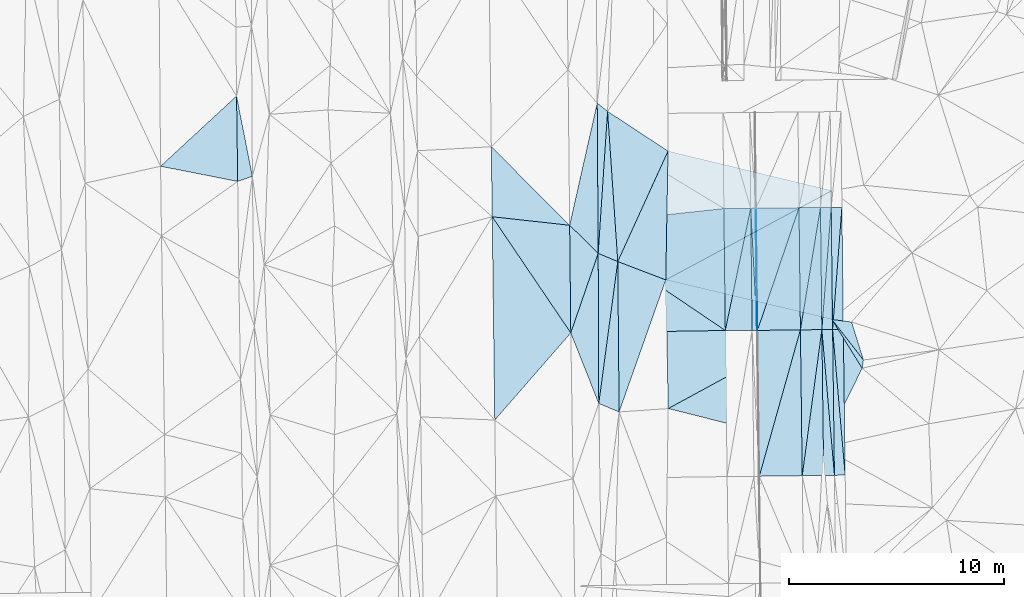
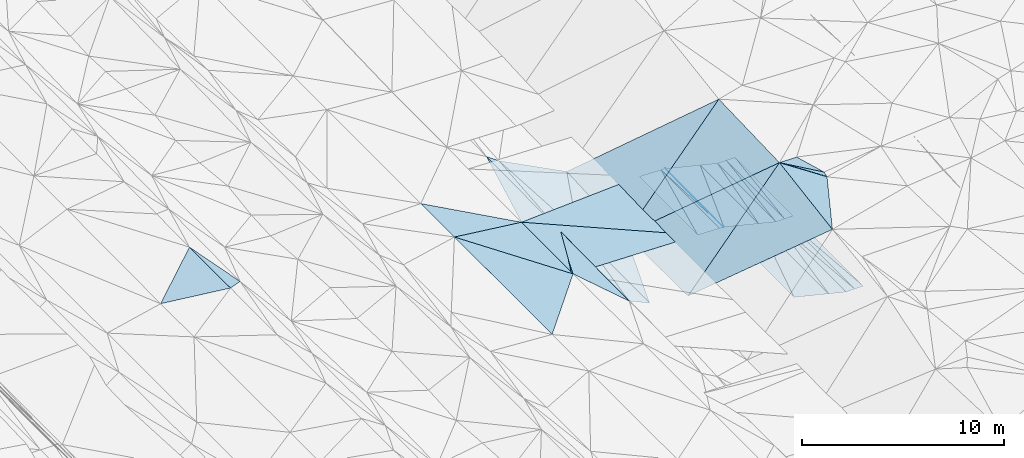
# One storey, part 34 of 275: 46 plates.
"""IFC2X3 building model written with IfcOpenShell, lengths in millimetres."""

from ifc_helpers import new_model, si_unit, frame, origin_with_axes, place, context, subcontext, project, spatial, polyline, outline, extrude, material, type_object, element, save


model = new_model("IFC2X3")

# Units and contexts
model_context = context("Model", 3, precision=1e-05, world=origin_with_axes())
body_context = subcontext(model_context, "Body", "Model", "MODEL_VIEW")
ifc_project = project(units=[si_unit("LENGTHUNIT", "METRE", prefix="MILLI"), si_unit("AREAUNIT", "SQUARE_METRE"), si_unit("VOLUMEUNIT", "CUBIC_METRE"), si_unit("MASSUNIT", "GRAM", prefix="KILO"), si_unit("TIMEUNIT", "SECOND"), si_unit("PLANEANGLEUNIT", "RADIAN"), si_unit("SOLIDANGLEUNIT", "STERADIAN"), si_unit("THERMODYNAMICTEMPERATUREUNIT", "DEGREE_CELSIUS"), si_unit("LUMINOUSINTENSITYUNIT", "LUMEN")], contexts=[model_context])

# Site, building, storey
site_placement = place(None, origin_with_axes())
site = spatial("IfcSite", under=ifc_project, at=site_placement, CompositionType="ELEMENT")
building_placement = place(site_placement, origin_with_axes())
building = spatial("IfcBuilding", under=site, at=building_placement, Name="Undefined", CompositionType="ELEMENT")
storey_placement = place(building_placement, origin_with_axes())
storey = spatial("IfcBuildingStorey", under=building, at=storey_placement, Name="Undefined", CompositionType="ELEMENT", Elevation=0.0)

# Plates
ifc_material = material()
plate_type_1 = type_object("IfcPlateType", PredefinedType="NOTDEFINED")
plate_1_placement = place(storey_placement, frame((-62138.0579087981, 8292.00278589061, 41120.5116137731), z_axis=(-0.213705537159807, 0.0166326658530718, -0.976756519207248), x_axis=(-0.904444932650548, 0.374508364674133, 0.204261715923109)))
element("IfcPlate", 1, at=plate_1_placement, inside=storey, type_object=plate_type_1, material=ifc_material, Name="00", context=body_context, shape_type="SweptSolid", body=[
    extrude(outline(polyline([(0.0, 0.0), (1047.67553710938, 2.97950464300811e-09), (2707.23706054688, 6462.1826171875), (0.0, 0.0)])), frame((-8.85201319254618e-08, 2.18876761149539e-07, -0.5000001331573), z_axis=(0.0, 0.0, 1.0), x_axis=(1.0, 0.0, 0.0)), (0.0, 0.0, 1.0), 1.0),
])
plate_type_2 = type_object("IfcPlateType", PredefinedType="NOTDEFINED")
plate_2_placement = place(storey_placement, frame((-55757.1571306949, 17783.4511288641, 41272.1487525771), z_axis=(-0.0501896607139265, 0.0218036376036795, -0.998501677186708), x_axis=(0.0115225950572727, -0.999682493231415, -0.0224085369840911)))
element("IfcPlate", 2, at=plate_2_placement, inside=storey, type_object=plate_type_2, material=ifc_material, Name="00_PR", context=body_context, shape_type="SweptSolid", body=[
    extrude(outline(polyline([(0.0, 0.0), (5694.8642578125, -3.17959347739816e-09), (5694.85107421875, 20.0251865386963), (0.0, 0.0)])), frame((-8.85201319254618e-08, 2.18876761149539e-07, -0.5000001331573), z_axis=(0.0, 0.0, 1.0), x_axis=(1.0, 0.0, 0.0)), (0.0, 0.0, 1.0), 1.0),
])
plate_3_placement = place(storey_placement, frame((-55711.5356164447, 12090.1551803275, 41145.5347521996), z_axis=(-0.0501703449300262, 0.0218038137157571, -0.998502644061122), x_axis=(-0.0115225950602647, 0.99968249323143, 0.0224085369819156)))
element("IfcPlate", 3, at=plate_3_placement, inside=storey, type_object=plate_type_2, material=ifc_material, Name="00_PR", context=body_context, shape_type="SweptSolid", body=[
    extrude(outline(polyline([(0.0, 0.0), (5694.8828125, -4.78030415251851e-09), (5694.85107421875, 20.0245056152344), (0.0, 0.0)])), frame((-8.85201319254618e-08, 2.18876761149539e-07, -0.5000001331573), z_axis=(0.0, 0.0, 1.0), x_axis=(1.0, 0.0, 0.0)), (0.0, 0.0, 1.0), 1.0),
])
plate_type_3 = type_object("IfcPlateType", PredefinedType="NOTDEFINED")
plate_4_placement = place(storey_placement, frame((-57191.5919974292, 12086.723146007, 41199.3753833085), z_axis=(-0.0323757136217727, 0.021699449340617, -0.999240184873384), x_axis=(-0.0115216010714505, 0.999689759473814, 0.0220825159784634)))
element("IfcPlate", 4, at=plate_4_placement, inside=storey, type_object=plate_type_3, material=ifc_material, Name="00_PR", context=body_context, shape_type="SweptSolid", body=[
    extrude(outline(polyline([(0.0, 0.0), (5681.916015625, -4.67844074591994e-09), (5680.43505859375, 1250.64526367188), (0.0, 0.0)])), frame((-8.85201319254618e-08, 2.18876761149539e-07, -0.5000001331573), z_axis=(0.0, 0.0, 1.0), x_axis=(1.0, 0.0, 0.0)), (0.0, 0.0, 1.0), 1.0),
])
plate_type_4 = type_object("IfcPlateType", PredefinedType="NOTDEFINED")
plate_5_placement = place(storey_placement, frame((-51757.3704409347, 17827.1303423786, 40522.1361300725), z_axis=(-0.000269112383078146, 0.0224219285941245, -0.999748560737471), x_axis=(0.0115226870498863, -0.999682155734291, -0.0224235409690707)))
element("IfcPlate", 5, at=plate_5_placement, inside=storey, type_object=plate_type_4, material=ifc_material, Name="00_PR", context=body_context, shape_type="SweptSolid", body=[
    extrude(outline(polyline([(0.0, 0.0), (5690.53759765625, -5.3114490583539e-10), (5690.775390625, 499.999969482422), (0.0, 0.0)])), frame((-8.85201319254618e-08, 2.18876761149539e-07, -0.5000001331573), z_axis=(0.0, 0.0, 1.0), x_axis=(1.0, 0.0, 0.0)), (0.0, 0.0, 1.0), 1.0),
])
plate_6_placement = place(storey_placement, frame((-51691.8001545929, 12138.4012421627, 40394.5341232157), z_axis=(-0.00026151167394506, 0.0217886602042513, -0.999762564761328), x_axis=(0.0125667630555542, -0.99968358119848, -0.0217902259852529)))
element("IfcPlate", 6, at=plate_6_placement, inside=storey, type_object=plate_type_4, material=ifc_material, Name="00_PR", context=body_context, shape_type="SweptSolid", body=[
    extrude(outline(polyline([(0.0, 0.0), (6794.05517578125, -5.5297277867794e-09), (-0.284165561199188, 499.999938964844), (0.0, 0.0)])), frame((-8.85201319254618e-08, 2.18876761149539e-07, -0.5000001331573), z_axis=(0.0, 0.0, 1.0), x_axis=(1.0, 0.0, 0.0)), (0.0, 0.0, 1.0), 1.0),
])
plate_7_placement = place(storey_placement, frame((-52257.3403949492, 17821.6748309293, 40522.1381299556), z_axis=(-0.000269090319910221, 0.0224201327367722, -0.999748601018509), x_axis=(0.0115226260505305, -0.999682196721102, -0.0224217449760555)))
element("IfcPlate", 7, at=plate_7_placement, inside=storey, type_object=plate_type_4, material=ifc_material, Name="00_PR", context=body_context, shape_type="SweptSolid", body=[
    extrude(outline(polyline([(0.0, 0.0), (5691.08251953125, -8.51287040859461e-10), (5691.3203125, 499.999969482422), (0.0, 0.0)])), frame((-8.85201319254618e-08, 2.18876761149539e-07, -0.5000001331573), z_axis=(0.0, 0.0, 1.0), x_axis=(1.0, 0.0, 0.0)), (0.0, 0.0, 1.0), 1.0),
])
plate_8_placement = place(storey_placement, frame((-52191.7641719808, 12132.4005785641, 40394.5341229141), z_axis=(-0.00026148970989037, 0.0217868403330459, -0.999762604427388), x_axis=(0.0125667600516061, -0.999683620905424, -0.0217884059817822)))
element("IfcPlate", 8, at=plate_8_placement, inside=storey, type_object=plate_type_4, material=ifc_material, Name="00_PR", context=body_context, shape_type="SweptSolid", body=[
    extrude(outline(polyline([(0.0, 0.0), (6794.623046875, 5.23868948221207e-10), (-0.284165561199188, 499.999938964844), (0.0, 0.0)])), frame((-8.85201319254618e-08, 2.18876761149539e-07, -0.5000001331573), z_axis=(0.0, 0.0, 1.0), x_axis=(1.0, 0.0, 0.0)), (0.0, 0.0, 1.0), 1.0),
])
plate_9_placement = place(storey_placement, frame((-52191.7641654545, 12132.4008952965, 40394.5341299456), z_axis=(-0.00024864254672807, 0.0224203684267961, -0.999748601027524), x_axis=(-0.0115226260502812, 0.999682196721041, 0.0224217449789295)))
element("IfcPlate", 9, at=plate_9_placement, inside=storey, type_object=plate_type_4, material=ifc_material, Name="00_PR", context=body_context, shape_type="SweptSolid", body=[
    extrude(outline(polyline([(0.0, 0.0), (5691.08251953125, -8.51287040859461e-10), (5690.775390625, 499.999633789063), (0.0, 0.0)])), frame((-8.85201319254618e-08, 2.18876761149539e-07, -0.5000001331573), z_axis=(0.0, 0.0, 1.0), x_axis=(1.0, 0.0, 0.0)), (0.0, 0.0, 1.0), 1.0),
])
plate_10_placement = place(storey_placement, frame((-52106.3777888769, 5339.92747869403, 40246.490123646), z_axis=(-0.000286223633870663, 0.0217865294104669, -0.99976260442781), x_axis=(-0.012566760052633, 0.999683620905387, 0.0217884059828509)))
element("IfcPlate", 10, at=plate_10_placement, inside=storey, type_object=plate_type_4, material=ifc_material, Name="00_PR", context=body_context, shape_type="SweptSolid", body=[
    extrude(outline(polyline([(0.0, 0.0), (6794.623046875, 5.23868948221207e-10), (0.28333967924118, 499.999969482422), (0.0, 0.0)])), frame((-8.85201319254618e-08, 2.18876761149539e-07, -0.5000001331573), z_axis=(0.0, 0.0, 1.0), x_axis=(1.0, 0.0, 0.0)), (0.0, 0.0, 1.0), 1.0),
])
plate_11_placement = place(storey_placement, frame((-52691.7281832722, 12126.4002318924, 40394.5341296253), z_axis=(-0.000247507640595815, 0.0224184873887308, -0.999748643491537), x_axis=(-0.0115226330566603, 0.999682239118624, 0.0224198509856044)))
element("IfcPlate", 11, at=plate_11_placement, inside=storey, type_object=plate_type_4, material=ifc_material, Name="00_PR", context=body_context, shape_type="SweptSolid", body=[
    extrude(outline(polyline([(0.0, 0.0), (5691.697265625, -2.97586666420102e-09), (5691.3203125, 499.999969482422), (0.0, 0.0)])), frame((-8.85201319254618e-08, 2.18876761149539e-07, -0.5000001331573), z_axis=(0.0, 0.0, 1.0), x_axis=(1.0, 0.0, 0.0)), (0.0, 0.0, 1.0), 1.0),
])
plate_12_placement = place(storey_placement, frame((-52606.3342935542, 5333.35827591358, 40246.490122734), z_axis=(-0.000286239894493537, 0.0217847060621401, -0.999762644155356), x_axis=(-0.0125668150543833, 0.999683659945128, 0.0217865829836503)))
element("IfcPlate", 12, at=plate_12_placement, inside=storey, type_object=plate_type_4, material=ifc_material, Name="00_PR", context=body_context, shape_type="SweptSolid", body=[
    extrude(outline(polyline([(0.0, 0.0), (6795.19140625, 2.99769453704357e-09), (0.284231781959534, 499.999572753906), (0.0, 0.0)])), frame((-8.85201319254618e-08, 2.18876761149539e-07, -0.5000001331573), z_axis=(0.0, 0.0, 1.0), x_axis=(1.0, 0.0, 0.0)), (0.0, 0.0, 1.0), 1.0),
])
plate_type_5 = type_object("IfcPlateType", PredefinedType="NOTDEFINED")
plate_13_placement = place(storey_placement, frame((-52757.432758799, 17816.287040118, 40522.156048808), z_axis=(-0.24272258316732, 0.018954469739051, -0.969910550358895), x_axis=(0.0115226330566228, -0.999682239118577, -0.0224198509876876)))
element("IfcPlate", 13, at=plate_13_placement, inside=storey, type_object=plate_type_5, material=ifc_material, Name="00_PR", context=body_context, shape_type="SweptSolid", body=[
    extrude(outline(polyline([(0.0, 0.0), (5691.697265625, -2.97586666420102e-09), (5686.56787109375, 1030.763671875), (0.0, 0.0)])), frame((-8.85201319254618e-08, 2.18876761149539e-07, -0.5000001331573), z_axis=(0.0, 0.0, 1.0), x_axis=(1.0, 0.0, 0.0)), (0.0, 0.0, 1.0), 1.0),
])
plate_14_placement = place(storey_placement, frame((-53691.7774473345, 12114.397173797, 40644.5490463085), z_axis=(-0.242702860984024, 0.0189511302028501, -0.969915550929154), x_axis=(-0.0115226460531056, 0.999682323892736, 0.0224160639799476)))
element("IfcPlate", 14, at=plate_14_placement, inside=storey, type_object=plate_type_5, material=ifc_material, Name="00_PR", context=body_context, shape_type="SweptSolid", body=[
    extrude(outline(polyline([(0.0, 0.0), (5692.92626953125, 1.88447302207351e-09), (5686.56884765625, 1030.75854492188), (0.0, 0.0)])), frame((-8.85201319254618e-08, 2.18876761149539e-07, -0.5000001331573), z_axis=(0.0, 0.0, 1.0), x_axis=(1.0, 0.0, 0.0)), (0.0, 0.0, 1.0), 1.0),
])
plate_type_6 = type_object("IfcPlateType", PredefinedType="NOTDEFINED")
plate_15_placement = place(storey_placement, frame((-52691.8494288233, 12126.3980659238, 40394.5490425122), z_axis=(-0.242739157688589, 0.0180865707839443, -0.96992297492219), x_axis=(0.0125668150550343, -0.999683659945175, -0.0217865829811212)))
element("IfcPlate", 15, at=plate_15_placement, inside=storey, type_object=plate_type_6, material=ifc_material, Name="00_PR", context=body_context, shape_type="SweptSolid", body=[
    extrude(outline(polyline([(0.0, 0.0), (6795.19140625, 2.99769453704357e-09), (6790.3125, 1030.76550292969), (0.0, 0.0)])), frame((-8.85201319254618e-08, 2.18876761149539e-07, -0.5000001331573), z_axis=(0.0, 0.0, 1.0), x_axis=(1.0, 0.0, 0.0)), (0.0, 0.0, 1.0), 1.0),
])
plate_16_placement = place(storey_placement, frame((-53606.3698353621, 5320.21859578189, 40496.5050397393), z_axis=(-0.242716658506496, 0.0180834629363604, -0.969928663382865), x_axis=(-0.0125667310580108, 0.999683740366121, 0.0217829409887263)))
element("IfcPlate", 16, at=plate_16_placement, inside=storey, type_object=plate_type_6, material=ifc_material, Name="00_PR", context=body_context, shape_type="SweptSolid", body=[
    extrude(outline(polyline([(0.0, 0.0), (6796.32763671875, -3.69618646800518e-09), (6790.3134765625, 1030.75891113281), (0.0, 0.0)])), frame((-8.85201319254618e-08, 2.18876761149539e-07, -0.5000001331573), z_axis=(0.0, 0.0, 1.0), x_axis=(1.0, 0.0, 0.0)), (0.0, 0.0, 1.0), 1.0),
])
plate_type_7 = type_object("IfcPlateType", PredefinedType="NOTDEFINED")
plate_17_placement = place(storey_placement, frame((-55757.2533881467, 17783.4496985537, 41272.1630461233), z_axis=(-0.242703151226861, 0.0189438785904624, -0.96991561996315), x_axis=(0.97008334451735, 0.0107032020452645, -0.24253607186563)))
element("IfcPlate", 17, at=plate_17_placement, inside=storey, type_object=plate_type_7, material=ifc_material, Name="00_PR", context=body_context, shape_type="SweptSolid", body=[
    extrude(outline(polyline([(0.0, 0.0), (2061.55322265625, 1.61162461154163e-09), (33.674201965332, 5694.7646484375), (0.0, 0.0)])), frame((-8.85201319254618e-08, 2.18876761149539e-07, -0.5000001331573), z_axis=(0.0, 0.0, 1.0), x_axis=(1.0, 0.0, 0.0)), (0.0, 0.0, 1.0), 1.0),
])
plate_type_8 = type_object("IfcPlateType", PredefinedType="NOTDEFINED")
plate_18_placement = place(storey_placement, frame((-53691.777454556, 12114.3967364293, 40644.5490394591), z_axis=(-0.242716663703458, 0.0180764072576774, -0.969928793603591), x_axis=(-0.269911201055133, -0.961605753400183, 0.0496217550338837)))
element("IfcPlate", 18, at=plate_18_placement, inside=storey, type_object=plate_type_8, material=ifc_material, Name="00_PR", context=body_context, shape_type="SweptSolid", body=[
    extrude(outline(polyline([(0.0, 0.0), (7092.77587890625, 4.22005541622639e-09), (587.67626953125, 1976.01501464844), (0.0, 0.0)])), frame((-8.85201319254618e-08, 2.18876761149539e-07, -0.5000001331573), z_axis=(0.0, 0.0, 1.0), x_axis=(1.0, 0.0, 0.0)), (0.0, 0.0, 1.0), 1.0),
])
plate_type_9 = type_object("IfcPlateType", PredefinedType="NOTDEFINED")
plate_19_placement = place(storey_placement, frame((-53757.3750342256, 17805.5149222273, 40772.1620487741), z_axis=(-0.242722613534099, 0.0189507918460375, -0.969910614627753), x_axis=(0.0115226460523618, -0.999682323892639, -0.0224160639846739)))
element("IfcPlate", 19, at=plate_19_placement, inside=storey, type_object=plate_type_9, material=ifc_material, Name="00_PR", context=body_context, shape_type="SweptSolid", body=[
    extrude(outline(polyline([(0.0, 0.0), (5692.92626953125, 1.88447302207351e-09), (5682.67041015625, 2061.52709960938), (0.0, 0.0)])), frame((-8.85201319254618e-08, 2.18876761149539e-07, -0.5000001331573), z_axis=(0.0, 0.0, 1.0), x_axis=(1.0, 0.0, 0.0)), (0.0, 0.0, 1.0), 1.0),
])
plate_type_10 = type_object("IfcPlateType", PredefinedType="NOTDEFINED")
plate_20_placement = place(storey_placement, frame((-53691.777454556, 12114.3967364293, 40644.5490394591), z_axis=(-0.242739285542901, 0.0180830552826414, -0.969923008473233), x_axis=(0.0125667310583062, -0.999683740366033, -0.0217829409925611)))
element("IfcPlate", 20, at=plate_20_placement, inside=storey, type_object=plate_type_10, material=ifc_material, Name="00_PR", context=body_context, shape_type="SweptSolid", body=[
    extrude(outline(polyline([(0.0, 0.0), (6796.32763671875, -3.69618646800518e-09), (6786.57275390625, 2061.52978515625), (0.0, 0.0)])), frame((-8.85201319254618e-08, 2.18876761149539e-07, -0.5000001331573), z_axis=(0.0, 0.0, 1.0), x_axis=(1.0, 0.0, 0.0)), (0.0, 0.0, 1.0), 1.0),
])
plate_type_11 = type_object("IfcPlateType", PredefinedType="NOTDEFINED")
plate_21_placement = place(storey_placement, frame((-55777.1554447904, 17783.2300572417, 41273.1487521668), z_axis=(-0.0501690196808299, 0.0218038304776276, -0.998502710282134), x_axis=(0.0115225950572727, -0.999682493231415, -0.0224085369840911)))
element("IfcPlate", 21, at=plate_21_placement, inside=storey, type_object=plate_type_11, material=ifc_material, Name="00_PR", context=body_context, shape_type="SweptSolid", body=[
    extrude(outline(polyline([(0.0, 0.0), (5694.8828125, -4.78030415251851e-09), (-0.366935342550278, 230.287582397461), (0.0, 0.0)])), frame((-8.85201319254618e-08, 2.18876761149539e-07, -0.5000001331573), z_axis=(0.0, 0.0, 1.0), x_axis=(1.0, 0.0, 0.0)), (0.0, 0.0, 1.0), 1.0),
])
plate_22_placement = place(storey_placement, frame((-55941.5195278428, 12087.3949602262, 41157.0347527088), z_axis=(-0.0501902498403676, 0.0218027021489395, -0.998501668000593), x_axis=(-0.0115225950602647, 0.99968249323143, 0.0224085369819156)))
element("IfcPlate", 22, at=plate_22_placement, inside=storey, type_object=plate_type_11, material=ifc_material, Name="00_PR", context=body_context, shape_type="SweptSolid", body=[
    extrude(outline(polyline([(0.0, 0.0), (5695.1015625, -7.7707227319479e-09), (-0.148359909653664, 230.287734985352), (0.0, 0.0)])), frame((-8.85201319254618e-08, 2.18876761149539e-07, -0.5000001331573), z_axis=(0.0, 0.0, 1.0), x_axis=(1.0, 0.0, 0.0)), (0.0, 0.0, 1.0), 1.0),
])
plate_type_12 = type_object("IfcPlateType", PredefinedType="NOTDEFINED")
plate_23_placement = place(storey_placement, frame((-56007.1338054137, 17780.6885472985, 41284.6484114126), z_axis=(-0.0338547974654509, 0.0220062935496309, -0.99918445530982), x_axis=(0.0115225950572727, -0.999682493231415, -0.0224085369840911)))
element("IfcPlate", 23, at=plate_23_placement, inside=storey, type_object=plate_type_12, material=ifc_material, Name="00_PR", context=body_context, shape_type="SweptSolid", body=[
    extrude(outline(polyline([(0.0, 0.0), (5695.1015625, -7.7707227319479e-09), (5680.42041015625, 1250.71228027344), (0.0, 0.0)])), frame((-8.85201319254618e-08, 2.18876761149539e-07, -0.5000001331573), z_axis=(0.0, 0.0, 1.0), x_axis=(1.0, 0.0, 0.0)), (0.0, 0.0, 1.0), 1.0),
])
plate_type_13 = type_object("IfcPlateType", PredefinedType="NOTDEFINED")
plate_24_placement = place(storey_placement, frame((-64442.6872788273, 16989.8392468186, 41541.8413852177), z_axis=(-0.0325217101266362, 0.0216976634599205, -0.999235482642014), x_axis=(0.993756122562069, 0.107462432013678, -0.0300099079656675)))
element("IfcPlate", 24, at=plate_24_placement, inside=storey, type_object=plate_type_13, material=ifc_material, Name="00_PR", context=body_context, shape_type="SweptSolid", body=[
    extrude(outline(polyline([(0.0, 0.0), (7230.7783203125, -1.73604348674417e-08), (6689.19677734375, 5656.0458984375), (0.0, 0.0)])), frame((-8.85201319254618e-08, 2.18876761149539e-07, -0.5000001331573), z_axis=(0.0, 0.0, 1.0), x_axis=(1.0, 0.0, 0.0)), (0.0, 0.0, 1.0), 1.0),
])
plate_type_14 = type_object("IfcPlateType", PredefinedType="NOTDEFINED")
plate_25_placement = place(storey_placement, frame((-57191.5926353403, 12086.7223100932, 41199.3753868266), z_axis=(-0.0336510981891546, 0.0200272631920113, -0.999232961986194), x_axis=(-0.999319222832846, -0.0158024230595781, 0.0333372809659499)))
element("IfcPlate", 25, at=plate_25_placement, inside=storey, type_object=plate_type_14, material=ifc_material, Name="00_PR", context=body_context, shape_type="SweptSolid", body=[
    extrude(outline(polyline([(0.0, 0.0), (7202.89697265625, -1.26237864606082e-09), (7180.0947265625, 5018.21240234375), (0.0, 0.0)])), frame((-8.85201319254618e-08, 2.18876761149539e-07, -0.5000001331573), z_axis=(0.0, 0.0, 1.0), x_axis=(1.0, 0.0, 0.0)), (0.0, 0.0, 1.0), 1.0),
])
plate_type_15 = type_object("IfcPlateType", PredefinedType="NOTDEFINED")
plate_26_placement = place(storey_placement, frame((-68050.4598185546, 17384.7843789453, 41669.5003689003), z_axis=(-0.0337726362115457, 0.0196210985795566, -0.999236919621095), x_axis=(0.559951232495849, -0.827778351526408, -0.0351797949198487)))
element("IfcPlate", 26, at=plate_26_placement, inside=storey, type_object=plate_type_15, material=ifc_material, Name="00", context=body_context, shape_type="SweptSolid", body=[
    extrude(outline(polyline([(0.0, 0.0), (6537.84375, -3.10174073092639e-08), (7912.97607421875, 5208.01416015625), (0.0, 0.0)])), frame((-8.85201319254618e-08, 2.18876761149539e-07, -0.5000001331573), z_axis=(0.0, 0.0, 1.0), x_axis=(1.0, 0.0, 0.0)), (0.0, 0.0, 1.0), 1.0),
])
plate_type_16 = type_object("IfcPlateType", PredefinedType="NOTDEFINED")
plate_27_placement = place(storey_placement, frame((-63112.9216526386, 15678.5451482003, 41470.5003369595), z_axis=(-0.0317748973484694, 0.0193068665074055, -0.999308561358382), x_axis=(0.00391532953976656, -0.999803341054531, -0.0194409210376434)))
element("IfcPlate", 27, at=plate_27_placement, inside=storey, type_object=plate_type_16, material=ifc_material, Name="00", context=body_context, shape_type="SweptSolid", body=[
    extrude(outline(polyline([(0.0, 0.0), (6995.5537109375, -6.17728801444173e-09), (3700.52172851563, 1291.814453125), (0.0, 0.0)])), frame((-8.85201319254618e-08, 2.18876761149539e-07, -0.5000001331573), z_axis=(0.0, 0.0, 1.0), x_axis=(1.0, 0.0, 0.0)), (0.0, 0.0, 1.0), 1.0),
])
plate_type_17 = type_object("IfcPlateType", PredefinedType="NOTDEFINED")
plate_28_placement = place(storey_placement, frame((-62200.7682559761, 15296.805353613, 41253.5131932399), z_axis=(-0.228115871546175, 0.00830897258070851, -0.973598536422165), x_axis=(-0.901052161928329, 0.377047870373347, 0.214335962757556)))
element("IfcPlate", 28, at=plate_28_placement, inside=storey, type_object=plate_type_17, material=ifc_material, Name="00", context=body_context, shape_type="SweptSolid", body=[
    extrude(outline(polyline([(0.0, 0.0), (1012.42926025391, -3.15230863634497e-09), (3102.9951171875, 6292.14990234375), (0.0, 0.0)])), frame((-8.85201319254618e-08, 2.18876761149539e-07, -0.5000001331573), z_axis=(0.0, 0.0, 1.0), x_axis=(1.0, 0.0, 0.0)), (0.0, 0.0, 1.0), 1.0),
])
plate_type_18 = type_object("IfcPlateType", PredefinedType="NOTDEFINED")
plate_29_placement = place(storey_placement, frame((-63113.0797805298, 15678.5437454183, 41470.5313181016), z_axis=(-0.348013388826819, 0.0164862955094037, -0.937344591523123), x_axis=(-0.00647397655198563, 0.999779258458834, 0.0199880460052822)))
element("IfcPlate", 29, at=plate_29_placement, inside=storey, type_object=plate_type_18, material=ifc_material, Name="00", context=body_context, shape_type="SweptSolid", body=[
    extrude(outline(polyline([(0.0, 0.0), (7004.1865234375, 3.72529029846191e-09), (6610.54833984375, 512.123779296875), (0.0, 0.0)])), frame((-8.85201319254618e-08, 2.18876761149539e-07, -0.5000001331573), z_axis=(0.0, 0.0, 1.0), x_axis=(1.0, 0.0, 0.0)), (0.0, 0.0, 1.0), 1.0),
])
plate_type_19 = type_object("IfcPlateType", PredefinedType="NOTDEFINED")
plate_30_placement = place(storey_placement, frame((-79961.6106988774, 23008.8302426385, 41819.5001573559), z_axis=(0.0163429770428651, 0.0203207482028842, -0.999659929322893), x_axis=(0.193128297559801, -0.981029935952079, -0.0167846789517625)))
element("IfcPlate", 30, at=plate_30_placement, inside=storey, type_object=plate_type_19, material=ifc_material, Name="00", context=body_context, shape_type="SweptSolid", body=[
    extrude(outline(polyline([(0.0, 0.0), (3813.00122070313, 7.27595761418343e-09), (3914.37060546875, 716.451110839844), (0.0, 0.0)])), frame((-8.85201319254618e-08, 2.18876761149539e-07, -0.5000001331573), z_axis=(0.0, 0.0, 1.0), x_axis=(1.0, 0.0, 0.0)), (0.0, 0.0, 1.0), 1.0),
])
plate_type_20 = type_object("IfcPlateType", PredefinedType="NOTDEFINED")
plate_31_placement = place(storey_placement, frame((-59859.4949440104, 20445.1025253504, 40908.5075136706), z_axis=(-0.172346282215135, 0.0123718980565661, -0.984958727635376), x_axis=(-0.413197716621482, -0.908603503436126, 0.0608877698917612)))
element("IfcPlate", 31, at=plate_31_placement, inside=storey, type_object=plate_type_20, material=ifc_material, Name="00", context=body_context, shape_type="SweptSolid", body=[
    extrude(outline(polyline([(0.0, 0.0), (5666.16259765625, -4.52564563602209e-09), (-485.124816894531, 3373.63208007813), (0.0, 0.0)])), frame((-8.85201319254618e-08, 2.18876761149539e-07, -0.5000001331573), z_axis=(0.0, 0.0, 1.0), x_axis=(1.0, 0.0, 0.0)), (0.0, 0.0, 1.0), 1.0),
])
plate_type_21 = type_object("IfcPlateType", PredefinedType="NOTDEFINED")
plate_32_placement = place(storey_placement, frame((-63158.2668862256, 22681.1857979154, 41610.5003510676), z_axis=(-0.0323575996362873, 0.019768552769641, -0.99928083643547), x_axis=(0.006473976541019, -0.999779258458126, -0.0199880460442322)))
element("IfcPlate", 32, at=plate_32_placement, inside=storey, type_object=plate_type_21, material=ifc_material, Name="00", context=body_context, shape_type="SweptSolid", body=[
    extrude(outline(polyline([(0.0, 0.0), (7004.1865234375, 3.72529029846191e-09), (5683.19482421875, 1321.93322753906), (0.0, 0.0)])), frame((-8.85201319254618e-08, 2.18876761149539e-07, -0.5000001331573), z_axis=(0.0, 0.0, 1.0), x_axis=(1.0, 0.0, 0.0)), (0.0, 0.0, 1.0), 1.0),
])
plate_type_22 = type_object("IfcPlateType", PredefinedType="NOTDEFINED")
plate_33_placement = place(storey_placement, frame((-50814.0892720339, 10325.3643220606, 43559.5042580553), z_axis=(0.116132576823548, 0.0593033157121526, -0.991461719556468), x_axis=(-0.526630358740016, 0.850025241962427, -0.0108421990426412)))
element("IfcPlate", 33, at=plate_33_placement, inside=storey, type_object=plate_type_22, material=ifc_material, Name="00", context=body_context, shape_type="SweptSolid", body=[
    extrude(outline(polyline([(0.0, 0.0), (2674.73413085938, -4.47471393272281e-10), (297.528625488281, 255.688705444336), (0.0, 0.0)])), frame((-8.85201319254618e-08, 2.18876761149539e-07, -0.5000001331573), z_axis=(0.0, 0.0, 1.0), x_axis=(1.0, 0.0, 0.0)), (0.0, 0.0, 1.0), 1.0),
])
plate_type_23 = type_object("IfcPlateType", PredefinedType="NOTDEFINED")
plate_34_placement = place(storey_placement, frame((-63085.6279861689, 8684.3667582103, 41334.5128043557), z_axis=(-0.224216004486498, 0.0180683620646621, -0.974371960610737), x_axis=(-0.00391532954918764, 0.999803341055295, 0.0194409209964738)))
element("IfcPlate", 34, at=plate_34_placement, inside=storey, type_object=plate_type_23, material=ifc_material, Name="00", context=body_context, shape_type="SweptSolid", body=[
    extrude(outline(polyline([(0.0, 0.0), (6995.5537109375, -6.17728801444173e-09), (6606.10400390625, 934.527648925781), (0.0, 0.0)])), frame((-8.85201319254618e-08, 2.18876761149539e-07, -0.5000001331573), z_axis=(0.0, 0.0, 1.0), x_axis=(1.0, 0.0, 0.0)), (0.0, 0.0, 1.0), 1.0),
])
plate_type_24 = type_object("IfcPlateType", PredefinedType="NOTDEFINED")
plate_35_placement = place(storey_placement, frame((-50755.4617333334, 10712.0916932386, 43589.5032510598), z_axis=(0.102976480406602, 0.0490101010819323, -0.993475643624446), x_axis=(-0.613668515294183, 0.789178061326438, -0.0246767270455153)))
element("IfcPlate", 35, at=plate_35_placement, inside=storey, type_object=plate_type_24, material=ifc_material, Name="00", context=body_context, shape_type="SweptSolid", body=[
    extrude(outline(polyline([(0.0, 0.0), (2390.91674804688, 1.77897163666785e-09), (1733.05908203125, 653.53369140625), (0.0, 0.0)])), frame((-8.85201319254618e-08, 2.18876761149539e-07, -0.5000001331573), z_axis=(0.0, 0.0, 1.0), x_axis=(1.0, 0.0, 0.0)), (0.0, 0.0, 1.0), 1.0),
])
plate_type_25 = type_object("IfcPlateType", PredefinedType="NOTDEFINED")
plate_36_placement = place(storey_placement, frame((-68092.7935773527, 20646.1648210179, 41729.500357844), z_axis=(-0.0340425481009596, 0.017941605381323, -0.999259327559735), x_axis=(0.706027093779876, -0.707230587825571, -0.0367510338989098)))
element("IfcPlate", 36, at=plate_36_placement, inside=storey, type_object=plate_type_25, material=ifc_material, Name="00", context=body_context, shape_type="SweptSolid", body=[
    extrude(outline(polyline([(0.0, 0.0), (5169.9228515625, -1.17142917588353e-09), (2338.64233398438, 2274.36840820313), (0.0, 0.0)])), frame((-8.85201319254618e-08, 2.18876761149539e-07, -0.5000001331573), z_axis=(0.0, 0.0, 1.0), x_axis=(1.0, 0.0, 0.0)), (0.0, 0.0, 1.0), 1.0),
])
plate_type_26 = type_object("IfcPlateType", PredefinedType="NOTDEFINED")
plate_37_placement = place(storey_placement, frame((-59859.5111512401, 20445.110121433, 40908.5107778861), z_axis=(-0.204756369373821, 0.0275485785463693, -0.978425216877062), x_axis=(-0.0175018784958987, -0.999547088570648, -0.0244806449885796)))
element("IfcPlate", 37, at=plate_37_placement, inside=storey, type_object=plate_type_26, material=ifc_material, Name="00", context=body_context, shape_type="SweptSolid", body=[
    extrude(outline(polyline([(0.0, 0.0), (6004.74365234375, 8.0326572060585e-09), (5178.49365234375, 2299.69555664063), (0.0, 0.0)])), frame((-8.85201319254618e-08, 2.18876761149539e-07, -0.5000001331573), z_axis=(0.0, 0.0, 1.0), x_axis=(1.0, 0.0, 0.0)), (0.0, 0.0, 1.0), 1.0),
])
plate_type_27 = type_object("IfcPlateType", PredefinedType="NOTDEFINED")
plate_38_placement = place(storey_placement, frame((-52634.3505444094, 6637.42744903572, 43252.502246261), z_axis=(0.0858547344095034, 0.0404934676794184, -0.995484426625937), x_axis=(0.0688127183357927, 0.99654664786828, 0.0464713720233673)))
element("IfcPlate", 38, at=plate_38_placement, inside=storey, type_object=plate_type_27, material=ifc_material, Name="00", context=body_context, shape_type="SweptSolid", body=[
    extrude(outline(polyline([(0.0, 0.0), (5982.177734375, 2.2846506908536e-09), (3814.71459960938, 1567.26098632813), (0.0, 0.0)])), frame((-8.85201319254618e-08, 2.18876761149539e-07, -0.5000001331573), z_axis=(0.0, 0.0, 1.0), x_axis=(1.0, 0.0, 0.0)), (0.0, 0.0, 1.0), 1.0),
])
plate_type_28 = type_object("IfcPlateType", PredefinedType="NOTDEFINED")
plate_39_placement = place(storey_placement, frame((-79961.6001535681, 23008.8303750685, 41819.5004397628), z_axis=(0.0374237342204635, 0.0205906666260085, -0.999087327797171), x_axis=(0.0133463416673937, -0.999708818847238, -0.020103549018956)))
element("IfcPlate", 39, at=plate_39_placement, inside=storey, type_object=plate_type_28, material=ifc_material, Name="00", context=body_context, shape_type="SweptSolid", body=[
    extrude(outline(polyline([(0.0, 0.0), (3979.39697265625, -4.40923031419516e-09), (3226.41845703125, 3585.72485351563), (0.0, 0.0)])), frame((-8.85201319254618e-08, 2.18876761149539e-07, -0.5000001331573), z_axis=(0.0, 0.0, 1.0), x_axis=(1.0, 0.0, 0.0)), (0.0, 0.0, 1.0), 1.0),
])
plate_type_29 = type_object("IfcPlateType", PredefinedType="NOTDEFINED")
plate_40_placement = place(storey_placement, frame((-68050.4598644777, 17384.78434768, 41669.500369761), z_axis=(-0.0338646377638175, 0.0195587829202874, -0.999235027568491), x_axis=(0.993424290921771, -0.108751081313523, -0.0357963757902282)))
element("IfcPlate", 40, at=plate_40_placement, inside=storey, type_object=plate_type_29, material=ifc_material, Name="00", context=body_context, shape_type="SweptSolid", body=[
    extrude(outline(polyline([(0.0, 0.0), (3631.65258789063, 7.80346454121172e-09), (4233.58251953125, 4981.9853515625), (0.0, 0.0)])), frame((-8.85201319254618e-08, 2.18876761149539e-07, -0.5000001331573), z_axis=(0.0, 0.0, 1.0), x_axis=(1.0, 0.0, 0.0)), (0.0, 0.0, 1.0), 1.0),
])
plate_type_30 = type_object("IfcPlateType", PredefinedType="NOTDEFINED")
plate_41_placement = place(storey_placement, frame((-64442.6873781936, 16989.8382109651, 41539.5003517777), z_axis=(-0.032549753086624, 0.0195735656219691, -0.999278434222836), x_axis=(0.711549609293928, -0.701665131529091, -0.036921493874455)))
element("IfcPlate", 41, at=plate_41_placement, inside=storey, type_object=plate_type_30, material=ifc_material, Name="00", context=body_context, shape_type="SweptSolid", body=[
    extrude(outline(polyline([(0.0, 0.0), (1868.830078125, 5.50062395632267e-09), (3561.68798828125, 3535.09228515625), (0.0, 0.0)])), frame((-8.85201319254618e-08, 2.18876761149539e-07, -0.5000001331573), z_axis=(0.0, 0.0, 1.0), x_axis=(1.0, 0.0, 0.0)), (0.0, 0.0, 1.0), 1.0),
])
plate_type_31 = type_object("IfcPlateType", PredefinedType="NOTDEFINED")
plate_42_placement = place(storey_placement, frame((-59964.6074531968, 14443.0806046236, 40761.511079047), z_axis=(-0.208766772588699, 0.0166971220909265, -0.977822908699105), x_axis=(-0.332654749400053, -0.94144660774498, 0.05494635990726)))
element("IfcPlate", 42, at=plate_42_placement, inside=storey, type_object=plate_type_31, material=ifc_material, Name="00", context=body_context, shape_type="SweptSolid", body=[
    extrude(outline(polyline([(0.0, 0.0), (6533.64501953125, 1.92085281014442e-09), (-32.8403205871582, 2443.4013671875), (0.0, 0.0)])), frame((-8.85201319254618e-08, 2.18876761149539e-07, -0.5000001331573), z_axis=(0.0, 0.0, 1.0), x_axis=(1.0, 0.0, 0.0)), (0.0, 0.0, 1.0), 1.0),
])
plate_type_32 = type_object("IfcPlateType", PredefinedType="NOTDEFINED")
plate_43_placement = place(storey_placement, frame((-59849.2861552635, 8447.63368364754, 40652.5302305713), z_axis=(0.341670214710966, 0.0236372207794479, -0.939522616105214), x_axis=(-0.0191821965524589, 0.999650811673604, 0.0181741039869386)))
element("IfcPlate", 43, at=plate_43_placement, inside=storey, type_object=plate_type_32, material=ifc_material, Name="00", context=body_context, shape_type="SweptSolid", body=[
    extrude(outline(polyline([(0.0, 0.0), (5997.54443359375, -4.80213202536106e-10), (4055.86279296875, 8199.5703125), (0.0, 0.0)])), frame((-8.85201319254618e-08, 2.18876761149539e-07, -0.5000001331573), z_axis=(0.0, 0.0, 1.0), x_axis=(1.0, 0.0, 0.0)), (0.0, 0.0, 1.0), 1.0),
])
plate_type_33 = type_object("IfcPlateType", PredefinedType="NOTDEFINED")
plate_44_placement = place(storey_placement, frame((-52223.5813928027, 18601.0727107168, 43729.5306197706), z_axis=(0.343190382267219, 0.031181807060802, -0.938748132582805), x_axis=(0.00016807655927062, -0.999450815159831, -0.0331366840015578)))
element("IfcPlate", 44, at=plate_44_placement, inside=storey, type_object=plate_type_33, material=ifc_material, Name="00", context=body_context, shape_type="SweptSolid", body=[
    extrude(outline(polyline([(0.0, 0.0), (6005.42919921875, -3.8635334931314e-09), (4252.75, 8242.0380859375), (0.0, 0.0)])), frame((-8.85201319254618e-08, 2.18876761149539e-07, -0.5000001331573), z_axis=(0.0, 0.0, 1.0), x_axis=(1.0, 0.0, 0.0)), (0.0, 0.0, 1.0), 1.0),
])
plate_type_34 = type_object("IfcPlateType", PredefinedType="NOTDEFINED")
plate_45_placement = place(storey_placement, frame((-59964.3280308288, 14443.0806588614, 40761.5317065393), z_axis=(0.35007611241744, 0.0168084716597148, -0.9365704409147), x_axis=(0.0175018784342891, 0.999547088571667, 0.0244806449909879)))
element("IfcPlate", 45, at=plate_45_placement, inside=storey, type_object=plate_type_34, material=ifc_material, Name="00", context=body_context, shape_type="SweptSolid", body=[
    extrude(outline(polyline([(0.0, 0.0), (6004.74365234375, 8.0326572060585e-09), (4364.23779296875, 8183.55078125), (0.0, 0.0)])), frame((-8.85201319254618e-08, 2.18876761149539e-07, -0.5000001331573), z_axis=(0.0, 0.0, 1.0), x_axis=(1.0, 0.0, 0.0)), (0.0, 0.0, 1.0), 1.0),
])
plate_type_35 = type_object("IfcPlateType", PredefinedType="NOTDEFINED")
plate_46_placement = place(storey_placement, frame((-52222.5719100105, 12598.9362846932, 43530.5305067266), z_axis=(0.34340246461612, 0.0200742665314449, -0.938973786172329), x_axis=(-0.0688127184249176, -0.996546647862778, -0.0464713720093766)))
element("IfcPlate", 46, at=plate_46_placement, inside=storey, type_object=plate_type_35, material=ifc_material, Name="00", context=body_context, shape_type="SweptSolid", body=[
    extrude(outline(polyline([(0.0, 0.0), (5982.177734375, 2.2846506908536e-09), (4795.52783203125, 7790.1142578125), (0.0, 0.0)])), frame((-8.85201319254618e-08, 2.18876761149539e-07, -0.5000001331573), z_axis=(0.0, 0.0, 1.0), x_axis=(1.0, 0.0, 0.0)), (0.0, 0.0, 1.0), 1.0),
])

save(model, "model.ifc")
